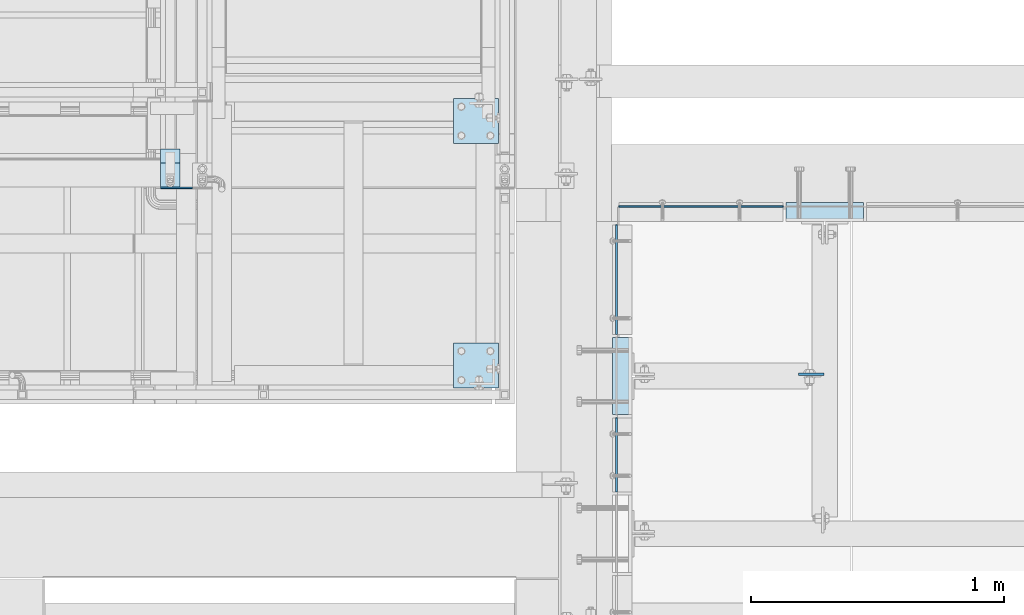
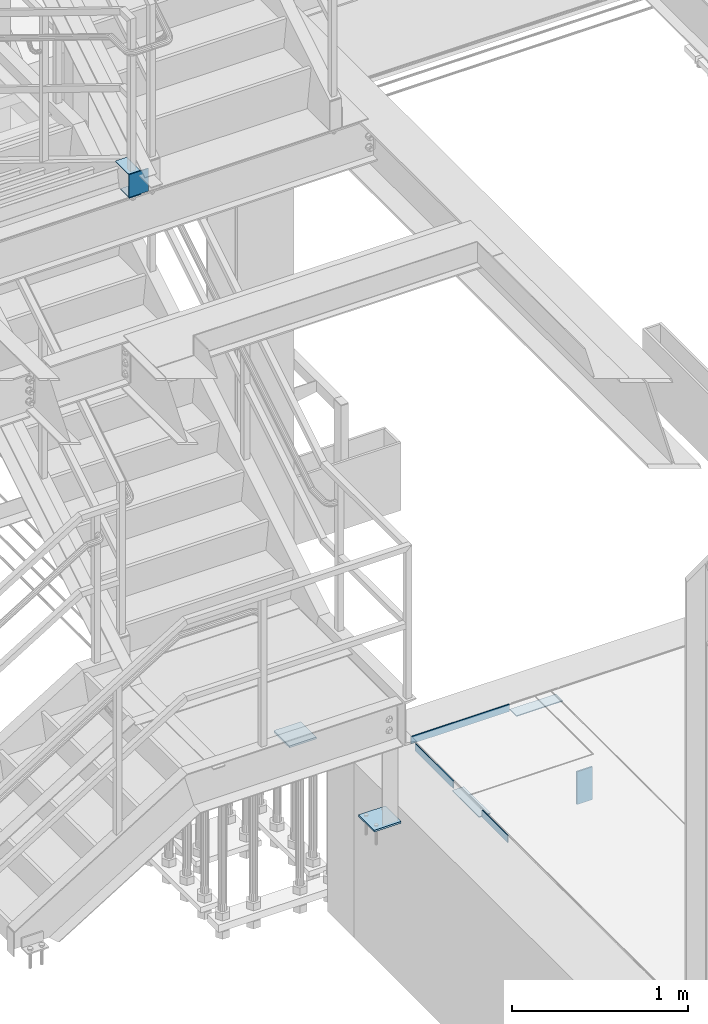
# One storey, part 3115 of 3843: 11 plates, 9 elements without a shape of their own.
"""IFC2X3 building model written with IfcOpenShell, lengths in millimetres."""

from ifc_helpers import new_model, si_unit, frame, origin_with_axes, place, context, subcontext, project, spatial, faceted_brep, material, type_object, element, aggregate, save


model = new_model("IFC2X3")

# Units and contexts
model_context = context("Model", 3, precision=1e-05, world=origin_with_axes())
body_context = subcontext(model_context, "Body", "Model", "MODEL_VIEW")
ifc_project = project(units=[si_unit("LENGTHUNIT", "METRE", prefix="MILLI"), si_unit("AREAUNIT", "SQUARE_METRE"), si_unit("VOLUMEUNIT", "CUBIC_METRE"), si_unit("MASSUNIT", "GRAM", prefix="KILO"), si_unit("TIMEUNIT", "SECOND"), si_unit("PLANEANGLEUNIT", "RADIAN"), si_unit("SOLIDANGLEUNIT", "STERADIAN"), si_unit("THERMODYNAMICTEMPERATUREUNIT", "DEGREE_CELSIUS"), si_unit("LUMINOUSINTENSITYUNIT", "LUMEN")], contexts=[model_context])

# Site, building, storey
site_placement = place(None, origin_with_axes())
site = spatial("IfcSite", under=ifc_project, at=site_placement, CompositionType="ELEMENT")
building_placement = place(site_placement, origin_with_axes())
building = spatial("IfcBuilding", under=site, at=building_placement, Name="Undefined", CompositionType="ELEMENT")
storey_placement = place(building_placement, origin_with_axes())
storey = spatial("IfcBuildingStorey", under=building, at=storey_placement, Name="Undefined", CompositionType="ELEMENT", Elevation=0.0)

# Assembly, plates
assembly_1_placement = place(storey_placement, origin_with_axes())
assembly_1 = element("IfcElementAssembly", 1, at=assembly_1_placement, inside=storey, Name="STAIR", AssemblyPlace="NOTDEFINED", PredefinedType="RIGID_FRAME")
ifc_material_1 = material(Name="STEEL/A36")
plate_type_1 = type_object("IfcPlateType", PredefinedType="NOTDEFINED")
plate_1_placement = place(assembly_1_placement, frame((54356.0000000233, 18923.0, 34813.875), z_axis=(0.0, -1.0, 0.0), x_axis=(-1.0, 0.0, 0.0)))
plate_1 = element("IfcPlate", 2, at=plate_1_placement, type_object=plate_type_1, material=ifc_material_1, Name="PLATE", context=body_context, shape_type="Brep", body=[
    faceted_brep([(0.0, -3.17499999999927, 0.0), (0.0, -3.17499999999927, 101.600000000006), (0.0, 3.17499999999927, 101.600000000006), (0.0, 3.17499999999927, 0.0), (76.1999999901309, -3.17500000000291, 101.599997261896), (76.1999999901309, 3.17500000000291, 101.599997261896), (76.1999999999971, -3.17499999999927, 0.0), (76.1999999999971, 3.17499999999927, 0.0)], [[[0, 1, 2, 3]], [[1, 4, 5, 2]], [[4, 6, 7, 5]], [[6, 0, 3, 7]], [[5, 7, 3, 2]], [[6, 4, 1, 0]]]),
])
plate_2_placement = place(assembly_1_placement, frame((54356.0000000232, 18978.6080215674, 34972.6249969323), z_axis=(0.0, -1.0, 0.0), x_axis=(-1.0, 0.0, 0.0)))
plate_2 = element("IfcPlate", 3, at=plate_2_placement, type_object=plate_type_1, material=ifc_material_1, Name="PLATE", context=body_context, shape_type="Brep", body=[
    faceted_brep([(0.0, -3.17499999999927, 0.0), (-9.88075044006109e-09, -3.17500000000291, 150.858021566859), (-9.88075044006109e-09, 3.17500000000291, 150.858021566859), (0.0, 3.17499999999927, 0.0), (76.1999999901309, -3.17500000000291, 150.85802157185), (76.1999999901309, 3.17500000000291, 150.85802157185), (76.1999999999971, -3.17499999999927, 0.0), (76.1999999999971, 3.17499999999927, 0.0)], [[[0, 1, 2, 3]], [[1, 4, 5, 2]], [[4, 6, 7, 5]], [[6, 0, 3, 7]], [[5, 7, 3, 2]], [[6, 4, 1, 0]]]),
])

# Assembly, plate
assembly_2_placement = place(storey_placement, origin_with_axes())
assembly_2 = element("IfcElementAssembly", 4, at=assembly_2_placement, inside=storey, Name="EMBED PLATE", AssemblyPlace="NOTDEFINED", PredefinedType="RIGID_FRAME")
plate_3_placement = place(assembly_2_placement, frame((56140.3500030518, 18234.025, 30426.025), z_axis=(0.0, -1.0, 0.0), x_axis=(-1.0, 0.0, 0.0)))
plate_3 = element("IfcPlate", 5, at=plate_3_placement, type_object=plate_type_1, material=ifc_material_1, Name="PLATE", context=body_context, shape_type="Brep", body=[
    faceted_brep([(0.0, -3.17499999999927, 0.0), (0.0, -3.17499999999927, 304.800000000003), (0.0, 3.17499999999927, 304.800000000003), (0.0, 3.17499999999927, 0.0), (76.1999999999971, -3.17499999999927, 304.799999999996), (76.1999999999971, 3.17499999999927, 304.799999999996), (76.1999999999971, -3.17499999999927, 0.0), (76.1999999999971, 3.17499999999927, 0.0)], [[[0, 1, 2, 3]], [[1, 4, 5, 2]], [[4, 6, 7, 5]], [[6, 0, 3, 7]], [[5, 7, 3, 2]], [[6, 4, 1, 0]]]),
])
aggregate(assembly_2, [plate_3])

assembly_3_placement = place(storey_placement, origin_with_axes())
assembly_3 = element("IfcElementAssembly", 6, at=assembly_3_placement, inside=storey, Name="EMBED PLATE", AssemblyPlace="NOTDEFINED", PredefinedType="RIGID_FRAME")
plate_4_placement = place(assembly_3_placement, frame((57054.75, 18691.225, 30426.025), z_axis=(-1.0, 0.0, 0.0), x_axis=(0.0, 1.0, 0.0)))
plate_4 = element("IfcPlate", 7, at=plate_4_placement, type_object=plate_type_1, material=ifc_material_1, Name="PLATE", context=body_context, shape_type="Brep", body=[
    faceted_brep([(0.0, -3.17499999999927, 0.0), (0.0, -3.17499999999927, 304.800000000003), (0.0, 3.17499999999927, 304.800000000003), (0.0, 3.17499999999927, 0.0), (76.1999999999971, -3.17499999999927, 304.799999999996), (76.1999999999971, 3.17499999999927, 304.799999999996), (76.1999999999971, -3.17499999999927, 0.0), (76.1999999999971, 3.17499999999927, 0.0)], [[[0, 1, 2, 3]], [[1, 4, 5, 2]], [[4, 6, 7, 5]], [[6, 0, 3, 7]], [[5, 7, 3, 2]], [[6, 4, 1, 0]]]),
])
aggregate(assembly_3, [plate_4])

assembly_4_placement = place(storey_placement, origin_with_axes())
assembly_4 = element("IfcElementAssembly", 8, at=assembly_4_placement, inside=storey, Name="POST", AssemblyPlace="NOTDEFINED", PredefinedType="RIGID_FRAME")
plate_type_2 = type_object("IfcPlateType", PredefinedType="NOTDEFINED")
plate_5_placement = place(assembly_4_placement, frame((55435.4999999891, 18211.800000064, 30486.35), z_axis=(1.0, 0.0, 0.0), x_axis=(0.0, -1.0, 0.0)))
plate_5 = element("IfcPlate", 9, at=plate_5_placement, type_object=plate_type_2, material=ifc_material_1, Name="PLATE", context=body_context, shape_type="Brep", body=[
    faceted_brep([(0.0, -6.3499999046162, 0.0), (0.0, -6.34999999999854, 177.799999999996), (0.0, 6.34999999999854, 177.799999999996), (7.27595761418343e-12, 6.3499999046162, 0.0), (177.800000000003, -6.34999999999854, 177.799999999996), (177.800000000003, 6.34999999999854, 177.799999999996), (177.800000000003, -6.34999999999854, 0.0), (177.800000000003, 6.34999999999854, 0.0)], [[[0, 1, 2, 3]], [[1, 4, 5, 2]], [[4, 6, 7, 5]], [[6, 0, 3, 7]], [[5, 7, 3, 2]], [[6, 4, 1, 0]]]),
])
aggregate(assembly_4, [plate_5])

assembly_5_placement = place(storey_placement, origin_with_axes())
assembly_5 = element("IfcElementAssembly", 10, at=assembly_5_placement, inside=storey, Name="POST", AssemblyPlace="NOTDEFINED", PredefinedType="RIGID_FRAME")
plate_6_placement = place(assembly_5_placement, frame((55613.299999989, 18999.2000001452, 30486.349999988), z_axis=(-1.0, 0.0, 0.0), x_axis=(0.0, 1.0, 0.0)))
plate_6 = element("IfcPlate", 11, at=plate_6_placement, type_object=plate_type_2, material=ifc_material_1, Name="PLATE", context=body_context, shape_type="Brep", body=[
    faceted_brep([(0.0, -6.3499999046162, 0.0), (0.0, -6.34999999999854, 177.799999999996), (0.0, 6.34999999999854, 177.799999999996), (7.27595761418343e-12, 6.3499999046162, 0.0), (177.800000000003, -6.34999999999854, 177.799999999996), (177.800000000003, 6.34999999999854, 177.799999999996), (177.800000000003, -6.34999999999854, 0.0), (177.800000000003, 6.34999999999854, 0.0)], [[[0, 1, 2, 3]], [[1, 4, 5, 2]], [[4, 6, 7, 5]], [[6, 0, 3, 7]], [[5, 7, 3, 2]], [[6, 4, 1, 0]]]),
])
aggregate(assembly_5, [plate_6])

assembly_6_placement = place(storey_placement, origin_with_axes())
assembly_6 = element("IfcElementAssembly", 12, at=assembly_6_placement, inside=storey, Name="ANGLE", AssemblyPlace="NOTDEFINED", PredefinedType="RIGID_FRAME")
plate_type_3 = type_object("IfcPlateType", PredefinedType="NOTDEFINED")
plate_7_placement = place(assembly_6_placement, frame((56080.0250159904, 17624.4249710295, 30429.2000030518), z_axis=(0.0, 0.999999999997942, -2.02899998962774e-06), x_axis=(0.0, 2.02899999567308e-06, 0.999999999997942)))
plate_7 = element("IfcPlate", 13, at=plate_7_placement, type_object=plate_type_3, material=ifc_material_1, Name="PLATE", context=body_context, shape_type="Brep", body=[
    faceted_brep([(0.0, -3.17499999999927, 0.0), (0.000588252398301847, -3.1750000006723, 292.099914550316), (0.000588252398301847, 3.17499999932625, 292.099914550308), (0.0, 3.17499999999927, 0.0), (50.8005867007196, -3.1750000006723, 292.099853515097), (50.8005867007196, 3.17499999932625, 292.09985351509), (50.7999954217848, -3.17499999999563, -7.27595761418343e-12), (50.7999954217848, 3.17500000001019, -1.09139364212751e-11)], [[[0, 1, 2, 3]], [[1, 4, 5, 2]], [[4, 6, 7, 5]], [[6, 0, 3, 7]], [[5, 7, 3, 2]], [[6, 4, 1, 0]]]),
])
aggregate(assembly_6, [plate_7])

assembly_7_placement = place(storey_placement, origin_with_axes())
assembly_7 = element("IfcElementAssembly", 14, at=assembly_7_placement, inside=storey, Name="ANGLE", AssemblyPlace="NOTDEFINED", PredefinedType="RIGID_FRAME")
plate_8_placement = place(assembly_7_placement, frame((56080.0250159904, 18246.7248982287, 30429.2000030518), z_axis=(0.0, 0.999999999997942, -2.02899998962774e-06), x_axis=(0.0, 2.02899999567308e-06, 0.999999999997942)))
plate_8 = element("IfcPlate", 15, at=plate_8_placement, type_object=plate_type_3, material=ifc_material_1, Name="PLATE", context=body_context, shape_type="Brep", body=[
    faceted_brep([(0.0, -3.17499999999927, 0.0), (0.000869328927365132, -3.17499999962456, 431.799987792274), (0.000869328927365132, 3.17500000038126, 431.79998779227), (0.0, 3.17499999999927, 0.0), (50.8008689884919, -3.17499999962456, 431.799926757056), (50.8008689884919, 3.17500000038126, 431.799926757052), (50.7999954217848, -3.17499999999563, -7.27595761418343e-12), (50.7999954217848, 3.17500000001019, -1.09139364212751e-11)], [[[0, 1, 2, 3]], [[1, 4, 5, 2]], [[4, 6, 7, 5]], [[6, 0, 3, 7]], [[5, 7, 3, 2]], [[6, 4, 1, 0]]]),
])
aggregate(assembly_7, [plate_8])

assembly_8_placement = place(storey_placement, origin_with_axes())
assembly_8 = element("IfcElementAssembly", 16, at=assembly_8_placement, inside=storey, Name="ANGLE", AssemblyPlace="NOTDEFINED", PredefinedType="RIGID_FRAME")
plate_9_placement = place(assembly_8_placement, frame((56089.5498725658, 18751.5499009176, 30429.2000030518), z_axis=(1.0, 0.0, 0.0), x_axis=(0.0, 0.0, 1.0)))
plate_9 = element("IfcPlate", 17, at=plate_9_placement, type_object=plate_type_3, material=ifc_material_1, Name="PLATE", context=body_context, shape_type="Brep", body=[
    faceted_brep([(0.0, -3.17499999999927, 0.0), (-1.9818249711534e-05, -3.17499999999927, 647.700134277329), (-1.9818249711534e-05, 3.17499999999927, 647.700134277329), (0.0, 3.17499999999927, 0.0), (50.7999839784352, -3.17499999999927, 647.700134277315), (50.7999839784352, 3.17499999999927, 647.700134277315), (50.7999954217848, -3.17499999999563, -7.27595761418343e-12), (50.7999954217848, 3.17500000001019, -1.09139364212751e-11)], [[[0, 1, 2, 3]], [[1, 4, 5, 2]], [[4, 6, 7, 5]], [[6, 0, 3, 7]], [[5, 7, 3, 2]], [[6, 4, 1, 0]]]),
])
aggregate(assembly_8, [plate_9])

# Plate
plate_type_4 = type_object("IfcPlateType", PredefinedType="NOTDEFINED")
plate_10_placement = place(assembly_1_placement, frame((54406.7999999698, 18824.5750000075, 34975.7999969323), z_axis=(-1.0, 0.0, 0.0), x_axis=(0.0, 0.0, -1.0)))
plate_10 = element("IfcPlate", 18, at=plate_10_placement, type_object=plate_type_4, material=ifc_material_1, Name="PLATE", context=body_context, shape_type="Brep", body=[
    faceted_brep([(0.0, -3.17499999999927, 0.0), (-6.10351708019152e-06, -3.17500000000291, 126.999993896483), (-6.10351708019152e-06, 3.17500000000291, 126.999993896483), (0.0, 3.17499999999927, 0.0), (158.74999693234, -3.17499999999927, 126.999999969747), (158.74999693234, 3.17499999999927, 126.999999969747), (158.749996174287, -3.17500000000291, -3.63797880709171e-11), (158.749996174287, 3.17500000000291, -3.63797880709171e-11)], [[[0, 1, 2, 3]], [[1, 4, 5, 2]], [[4, 6, 7, 5]], [[6, 0, 3, 7]], [[5, 7, 3, 2]], [[6, 4, 1, 0]]]),
])

aggregate(assembly_1, [plate_1, plate_10, plate_2])

# Assembly, plate
assembly_9_placement = place(storey_placement, origin_with_axes())
assembly_9 = element("IfcElementAssembly", 19, at=assembly_9_placement, inside=storey, Name="BEAM", AssemblyPlace="NOTDEFINED", PredefinedType="RIGID_FRAME")
ifc_material_2 = material(Name="STEEL/A572-50")
plate_type_5 = type_object("IfcPlateType", PredefinedType="NOTDEFINED")
plate_11_placement = place(assembly_9_placement, frame((56899.175, 18089.5625, 30391.1), z_axis=(-1.0, 0.0, 0.0), x_axis=(0.0, 0.0, -1.0)))
plate_11 = element("IfcPlate", 20, at=plate_11_placement, type_object=plate_type_5, material=ifc_material_2, Name="PLATE", context=body_context, shape_type="Brep", body=[
    faceted_brep([(0.0, -4.76249999999709, 0.0), (0.0, -4.76249999999709, 101.599999999999), (0.0, 4.76249999999709, 101.599999999999), (0.0, 4.76249999999709, 0.0), (228.600006103516, -4.76249999999709, 101.599998474121), (228.600006103516, 4.76249999999709, 101.599998474121), (228.600006103079, -4.7625000004482, 7.27595761418343e-12), (228.600006103079, 4.76249999954598, -7.27595761418343e-12)], [[[0, 1, 2, 3]], [[1, 4, 5, 2]], [[4, 6, 7, 5]], [[6, 0, 3, 7]], [[5, 7, 3, 2]], [[6, 4, 1, 0]]]),
])
aggregate(assembly_9, [plate_11])

save(model, "model.ifc")
